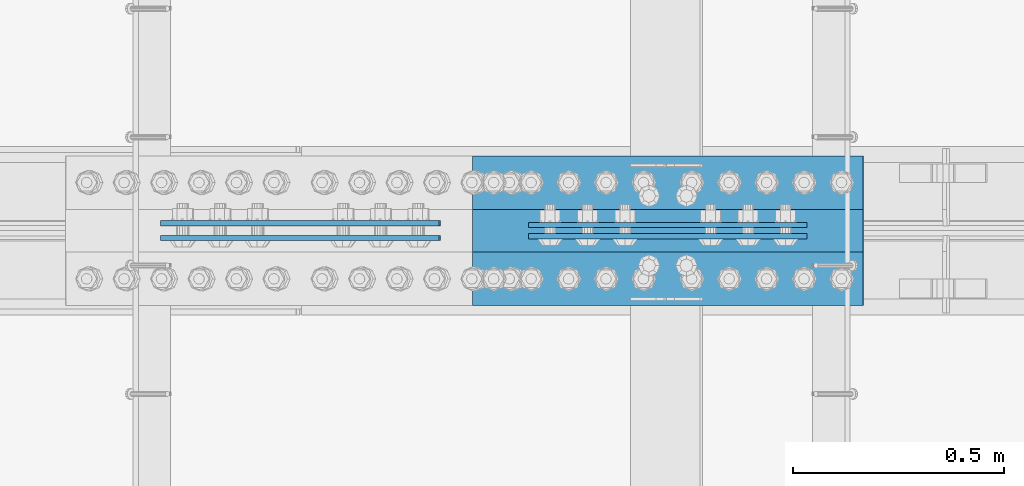
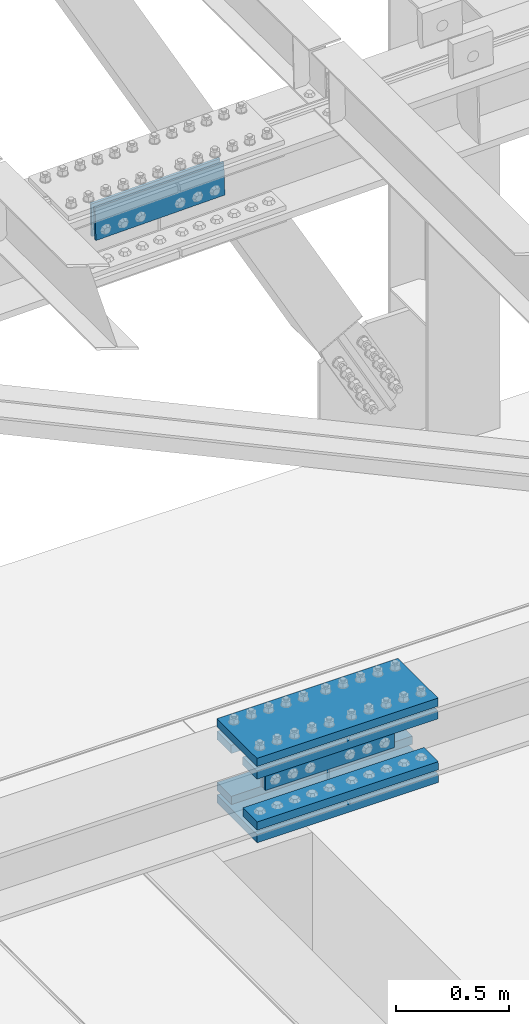
# One storey, part 2445 of 3843: 10 beams, 2 elements without a shape of their own.
"""IFC2X3 building model written with IfcOpenShell, lengths in millimetres."""

from ifc_helpers import new_model, si_unit, frame, origin_with_axes, place, context, subcontext, project, spatial, faceted_brep, material, type_object, element, aggregate, save


model = new_model("IFC2X3")

# Units and contexts
model_context = context("Model", 3, precision=1e-05, world=origin_with_axes())
body_context = subcontext(model_context, "Body", "Model", "MODEL_VIEW")
ifc_project = project(units=[si_unit("LENGTHUNIT", "METRE", prefix="MILLI"), si_unit("AREAUNIT", "SQUARE_METRE"), si_unit("VOLUMEUNIT", "CUBIC_METRE"), si_unit("MASSUNIT", "GRAM", prefix="KILO"), si_unit("TIMEUNIT", "SECOND"), si_unit("PLANEANGLEUNIT", "RADIAN"), si_unit("SOLIDANGLEUNIT", "STERADIAN"), si_unit("THERMODYNAMICTEMPERATUREUNIT", "DEGREE_CELSIUS"), si_unit("LUMINOUSINTENSITYUNIT", "LUMEN")], contexts=[model_context])

# Site, building, storey
site_placement = place(None, origin_with_axes())
site = spatial("IfcSite", under=ifc_project, at=site_placement, CompositionType="ELEMENT")
building_placement = place(site_placement, origin_with_axes())
building = spatial("IfcBuilding", under=site, at=building_placement, Name="Undefined", CompositionType="ELEMENT")
storey_placement = place(building_placement, origin_with_axes())
storey = spatial("IfcBuildingStorey", under=building, at=storey_placement, Name="Undefined", CompositionType="ELEMENT", Elevation=0.0)

# Assembly, beams
assembly_1_placement = place(storey_placement, origin_with_axes())
assembly_1 = element("IfcElementAssembly", 1, at=assembly_1_placement, inside=storey, Name="BEAM", AssemblyPlace="NOTDEFINED", PredefinedType="RIGID_FRAME")
ifc_material = material(Name="STEEL/A572-50")
beam_type_1 = type_object("IfcBeamType", PredefinedType="NOTDEFINED")
beam_1_placement = place(assembly_1_placement, frame((52793.8988414677, 75641.99375, 42309.1570925438), z_axis=(0.00254243700000369, 0.0, -0.999996768001828), x_axis=(-0.999996768001828, 0.0, -0.00254243700000061)))
beam_1 = element("IfcBeam", 2, at=beam_1_placement, type_object=beam_type_1, material=ifc_material, Name="PLATE", context=body_context, shape_type="Brep", body=[
    faceted_brep([(1.45519152283669e-11, 6.35000000000582, -88.8999999998996), (0.0, 6.34999999999854, 88.9000015258789), (660.399999982677, 6.35000000000582, 88.8999999999651), (660.399999982707, 6.35000000000582, -88.8999999998268), (0.0, -6.34999999999854, 88.9000015258789), (660.399999982677, -6.35000000000582, 88.8999999999651), (1.45519152283669e-11, -6.35000000000582, -88.8999999998996), (660.399999982707, -6.35000000000582, -88.8999999998268)], [[[0, 1, 2, 3]], [[1, 4, 5, 2]], [[4, 6, 7, 5]], [[6, 0, 3, 7]], [[5, 7, 3, 2]], [[6, 4, 1, 0]]]),
])
beam_2_placement = place(assembly_1_placement, frame((52793.8988414677, 75615.00625, 42309.1570925438), z_axis=(0.00254243700000369, 0.0, -0.999996768001828), x_axis=(-0.999996768001828, 0.0, -0.00254243700000061)))
beam_2 = element("IfcBeam", 3, at=beam_2_placement, type_object=beam_type_1, material=ifc_material, Name="PLATE", context=body_context, shape_type="Brep", body=[
    faceted_brep([(1.45519152283669e-11, 6.35000000000582, -88.8999999998996), (0.0, 6.34999999999854, 88.9000015258789), (660.399999982677, 6.35000000000582, 88.8999999999651), (660.399999982707, 6.35000000000582, -88.8999999998268), (0.0, -6.34999999999854, 88.9000015258789), (660.399999982677, -6.35000000000582, 88.8999999999651), (1.45519152283669e-11, -6.35000000000582, -88.8999999998996), (660.399999982707, -6.35000000000582, -88.8999999998268)], [[[0, 1, 2, 3]], [[1, 4, 5, 2]], [[4, 6, 7, 5]], [[6, 0, 3, 7]], [[5, 7, 3, 2]], [[6, 4, 1, 0]]]),
])

assembly_2_placement = place(storey_placement, origin_with_axes())
assembly_2 = element("IfcElementAssembly", 4, at=assembly_2_placement, inside=storey, Name="BEAM", AssemblyPlace="NOTDEFINED", PredefinedType="RIGID_FRAME")
beam_3_placement = place(assembly_2_placement, frame((51922.1993638938, 75645.9625, 45606.5187201096), z_axis=(0.023840473988268, 0.0, -0.999715775508227), x_axis=(-0.999715775508227, 0.0, -0.0238404739882678)))
beam_3 = element("IfcBeam", 5, at=beam_3_placement, type_object=beam_type_1, material=ifc_material, Name="PLATE", context=body_context, shape_type="Brep", body=[
    faceted_brep([(1.45519152283669e-11, 6.35000000000582, -88.8999999998996), (0.0, 6.34999999999854, 88.9000015258789), (660.399999982677, 6.35000000000582, 88.8999999999651), (660.399999982707, 6.35000000000582, -88.8999999998268), (0.0, -6.34999999999854, 88.9000015258789), (660.399999982677, -6.35000000000582, 88.8999999999651), (1.45519152283669e-11, -6.35000000000582, -88.8999999998996), (660.399999982707, -6.35000000000582, -88.8999999998268)], [[[0, 1, 2, 3]], [[1, 4, 5, 2]], [[4, 6, 7, 5]], [[6, 0, 3, 7]], [[5, 7, 3, 2]], [[6, 4, 1, 0]]]),
])
beam_4_placement = place(assembly_2_placement, frame((51922.1993638938, 75611.0375, 45606.5187201096), z_axis=(0.023840473988268, 0.0, -0.999715775508227), x_axis=(-0.999715775508227, 0.0, -0.0238404739882678)))
beam_4 = element("IfcBeam", 6, at=beam_4_placement, type_object=beam_type_1, material=ifc_material, Name="PLATE", context=body_context, shape_type="Brep", body=[
    faceted_brep([(1.45519152283669e-11, 6.35000000000582, -88.8999999998996), (0.0, 6.34999999999854, 88.9000015258789), (660.399999982677, 6.35000000000582, 88.8999999999651), (660.399999982707, 6.35000000000582, -88.8999999998268), (0.0, -6.34999999999854, 88.9000015258789), (660.399999982677, -6.35000000000582, 88.8999999999651), (1.45519152283669e-11, -6.35000000000582, -88.8999999998996), (660.399999982707, -6.35000000000582, -88.8999999998268)], [[[0, 1, 2, 3]], [[1, 4, 5, 2]], [[4, 6, 7, 5]], [[6, 0, 3, 7]], [[5, 7, 3, 2]], [[6, 4, 1, 0]]]),
])
aggregate(assembly_2, [beam_3, beam_4])

# Beam
beam_type_2 = type_object("IfcBeamType", PredefinedType="NOTDEFINED")
beam_5_placement = place(assembly_1_placement, frame((52926.7237171898, 75628.5, 42515.8696088097), z_axis=(0.0, -1.0, 0.0), x_axis=(-0.999996768001828, 0.0, -0.00254243700000061)))
beam_5 = element("IfcBeam", 7, at=beam_5_placement, type_object=beam_type_2, material=ifc_material, Name="PLATE", context=body_context, shape_type="Brep", body=[
    faceted_brep([(0.0, 22.2249999999767, -177.800000000003), (0.0, 22.2249999999767, 177.800000000003), (927.099999958984, 22.2250000000859, 177.800000000003), (927.099999958984, 22.2250000000859, -177.800000000003), (0.0, -22.2249999999694, 177.800000000003), (927.099999958984, -22.2249999998749, 177.800000000003), (0.0, -22.2249999999694, -177.800000000003), (927.099999958984, -22.2249999998749, -177.800000000003)], [[[0, 1, 2, 3]], [[1, 4, 5, 2]], [[4, 6, 7, 5]], [[6, 0, 3, 7]], [[5, 7, 3, 2]], [[6, 4, 1, 0]]]),
])

beam_6_placement = place(assembly_1_placement, frame((52927.7759415153, 75628.5, 42103.0617454567), z_axis=(0.0, -1.0, 0.0), x_axis=(-0.999996768001828, 0.0, -0.00254243700000061)))
beam_6 = element("IfcBeam", 8, at=beam_6_placement, type_object=beam_type_2, material=ifc_material, Name="PLATE", context=body_context, shape_type="Brep", body=[
    faceted_brep([(0.0, 22.2249999999767, -177.800000000003), (0.0, 22.2249999999767, 177.800000000003), (927.099999958984, 22.2250000000859, 177.800000000003), (927.099999958984, 22.2250000000859, -177.800000000003), (0.0, -22.2249999999694, 177.800000000003), (927.099999958984, -22.2249999998749, 177.800000000003), (0.0, -22.2249999999694, -177.800000000003), (927.099999958984, -22.2249999998749, -177.800000000003)], [[[0, 1, 2, 3]], [[1, 4, 5, 2]], [[4, 6, 7, 5]], [[6, 0, 3, 7]], [[5, 7, 3, 2]], [[6, 4, 1, 0]]]),
])

beam_type_3 = type_object("IfcBeamType", PredefinedType="NOTDEFINED")
beam_7_placement = place(assembly_1_placement, frame((51999.8004223986, 75742.8, 42445.1889851801), z_axis=(0.0, -1.0, 0.0), x_axis=(0.999996768001828, 0.0, 0.00254243700000616)))
beam_7 = element("IfcBeam", 9, at=beam_7_placement, type_object=beam_type_3, material=ifc_material, Name="PLATE", context=body_context, shape_type="Brep", body=[
    faceted_brep([(-7.27595761418343e-11, 22.2250000000786, -63.5), (-7.27595761418343e-11, 22.2250000000786, 63.5), (927.099999951592, 22.2250000031054, 63.5), (927.099999951592, 22.2250000031054, -63.5), (6.54836185276508e-11, -22.2250000000713, 63.5), (927.099999951744, -22.2249999970372, 63.5), (6.54836185276508e-11, -22.2250000000713, -63.5), (927.099999951744, -22.2249999970372, -63.5)], [[[0, 1, 2, 3]], [[1, 4, 5, 2]], [[4, 6, 7, 5]], [[6, 0, 3, 7]], [[5, 7, 3, 2]], [[6, 4, 1, 0]]]),
])

beam_8_placement = place(assembly_1_placement, frame((52000.5027018816, 75742.8, 42168.9669249213), z_axis=(0.0, -1.0, 0.0), x_axis=(0.999996768001828, 0.0, 0.00254243700000616)))
beam_8 = element("IfcBeam", 10, at=beam_8_placement, type_object=beam_type_3, material=ifc_material, Name="PLATE", context=body_context, shape_type="Brep", body=[
    faceted_brep([(-7.27595761418343e-11, 22.2250000000786, -63.5), (-7.27595761418343e-11, 22.2250000000786, 63.5), (927.099999951592, 22.2250000031054, 63.5), (927.099999951592, 22.2250000031054, -63.5), (6.54836185276508e-11, -22.2250000000713, 63.5), (927.099999951744, -22.2249999970372, 63.5), (6.54836185276508e-11, -22.2250000000713, -63.5), (927.099999951744, -22.2249999970372, -63.5)], [[[0, 1, 2, 3]], [[1, 4, 5, 2]], [[4, 6, 7, 5]], [[6, 0, 3, 7]], [[5, 7, 3, 2]], [[6, 4, 1, 0]]]),
])

beam_9_placement = place(assembly_1_placement, frame((51999.8004223986, 75514.2, 42445.1889851801), z_axis=(0.0, -1.0, 0.0), x_axis=(0.999996768001828, 0.0, 0.00254243700000616)))
beam_9 = element("IfcBeam", 11, at=beam_9_placement, type_object=beam_type_3, material=ifc_material, Name="PLATE", context=body_context, shape_type="Brep", body=[
    faceted_brep([(-7.27595761418343e-11, 22.2250000000786, -63.5), (-7.27595761418343e-11, 22.2250000000786, 63.5), (927.099999951592, 22.2250000031054, 63.5), (927.099999951592, 22.2250000031054, -63.5), (6.54836185276508e-11, -22.2250000000713, 63.5), (927.099999951744, -22.2249999970372, 63.5), (6.54836185276508e-11, -22.2250000000713, -63.5), (927.099999951744, -22.2249999970372, -63.5)], [[[0, 1, 2, 3]], [[1, 4, 5, 2]], [[4, 6, 7, 5]], [[6, 0, 3, 7]], [[5, 7, 3, 2]], [[6, 4, 1, 0]]]),
])

beam_10_placement = place(assembly_1_placement, frame((52000.5027018816, 75514.2, 42168.9669249213), z_axis=(0.0, -1.0, 0.0), x_axis=(0.999996768001828, 0.0, 0.00254243700000616)))
beam_10 = element("IfcBeam", 12, at=beam_10_placement, type_object=beam_type_3, material=ifc_material, Name="PLATE", context=body_context, shape_type="Brep", body=[
    faceted_brep([(-7.27595761418343e-11, 22.2250000000786, -63.5), (-7.27595761418343e-11, 22.2250000000786, 63.5), (927.099999951592, 22.2250000031054, 63.5), (927.099999951592, 22.2250000031054, -63.5), (6.54836185276508e-11, -22.2250000000713, 63.5), (927.099999951744, -22.2249999970372, 63.5), (6.54836185276508e-11, -22.2250000000713, -63.5), (927.099999951744, -22.2249999970372, -63.5)], [[[0, 1, 2, 3]], [[1, 4, 5, 2]], [[4, 6, 7, 5]], [[6, 0, 3, 7]], [[5, 7, 3, 2]], [[6, 4, 1, 0]]]),
])

aggregate(assembly_1, [beam_1, beam_2, beam_7, beam_8, beam_9, beam_10, beam_5, beam_6])

save(model, "model.ifc")
